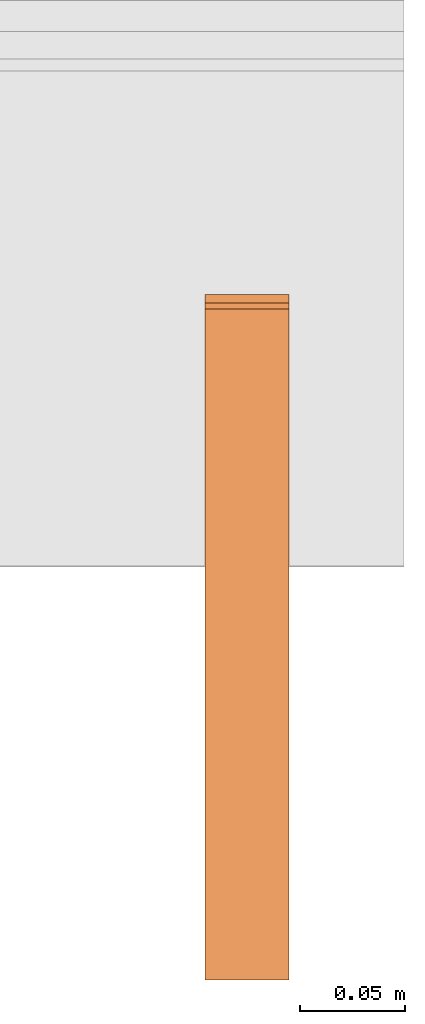
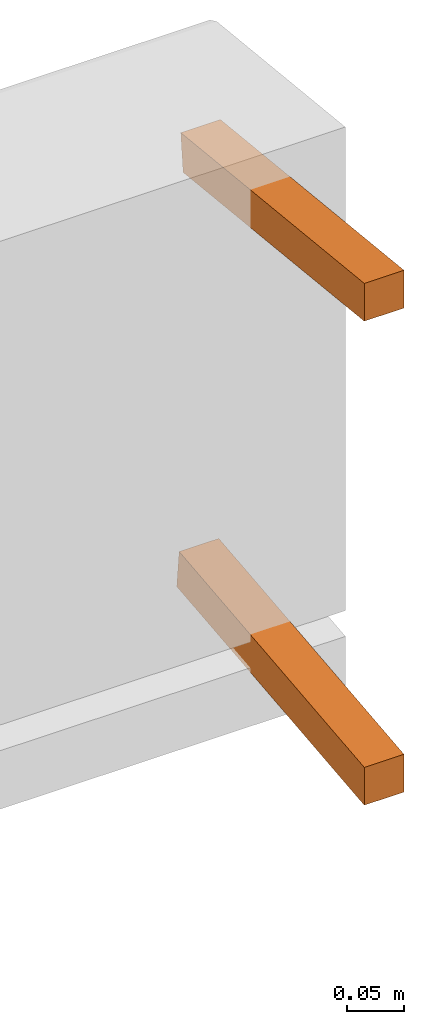
# One storey, part 2 of 2: 2 proxies, 1 element without a shape of its own.
"""IFC2X3 building model written with IfcOpenShell, lengths in metres."""

from ifc_helpers import new_model, si_unit, direction, origin_with_axes, place, context, project, spatial, faceted_brep, source, transform, mapped, element, aggregate, save


model = new_model("IFC2X3")

# Units and contexts
model_context = context("Model", 3, precision=1e-06, world=origin_with_axes(), true_north=direction((0.0, 1.0, 0.0)))
ifc_project = project(units=[si_unit("LENGTHUNIT", "METRE"), si_unit("AREAUNIT", "SQUARE_METRE"), si_unit("VOLUMEUNIT", "CUBIC_METRE")], contexts=[model_context])

# Site, building, storey
site_placement = place(None, origin_with_axes())
site = spatial("IfcSite", under=ifc_project, at=site_placement, CompositionType="ELEMENT")
building_placement = place(site_placement, origin_with_axes())
building = spatial("IfcBuilding", under=site, at=building_placement, Name="Default Building", CompositionType="ELEMENT")
storey_placement = place(building_placement, origin_with_axes())
storey = spatial("IfcBuildingStorey", under=building, at=storey_placement, Name="Default Storey", CompositionType="ELEMENT", Elevation=0.0)

# Assembly, proxies
assembly_placement = place(storey_placement, origin_with_axes())
assembly = element("IfcElementAssembly", 1, at=assembly_placement, inside=storey, AssemblyPlace="NOTDEFINED", PredefinedType="NOTDEFINED")
shared_shape_1 = source(origin_with_axes(), model_context, "Body", "Brep", [
    faceted_brep([(0.550000011920929, -0.3086836636066437, 0.203923761844635), (0.550000011920929, -0.3086836636066437, 0.24414409697055817), (0.5099999904632568, -0.3086836636066437, 0.203923761844635), (0.5099999904632568, -0.3086836636066437, 0.203923761844635), (0.550000011920929, -0.3086836636066437, 0.24414409697055817), (0.5099999904632568, -0.3086836636066437, 0.24414409697055817), (0.550000011920929, 0.00747277494519949, 0.17069438099861145), (0.550000011920929, -0.3086836636066437, 0.203923761844635), (0.5099999904632568, 0.00747277494519949, 0.17069438099861145), (0.5099999904632568, 0.00747277494519949, 0.17069438099861145), (0.550000011920929, -0.3086836636066437, 0.203923761844635), (0.5099999904632568, -0.3086836636066437, 0.203923761844635), (0.550000011920929, 0.011653914116322994, 0.21047525107860565), (0.550000011920929, 0.00747277494519949, 0.17069438099861145), (0.5099999904632568, 0.011653914116322994, 0.21047525107860565), (0.5099999904632568, 0.011653914116322994, 0.21047525107860565), (0.550000011920929, 0.00747277494519949, 0.17069438099861145), (0.5099999904632568, 0.00747277494519949, 0.17069438099861145), (0.550000011920929, -0.3086836636066437, 0.24414409697055817), (0.550000011920929, 0.011653914116322994, 0.21047525107860565), (0.5099999904632568, -0.3086836636066437, 0.24414409697055817), (0.5099999904632568, -0.3086836636066437, 0.24414409697055817), (0.550000011920929, 0.011653914116322994, 0.21047525107860565), (0.5099999904632568, 0.011653914116322994, 0.21047525107860565), (0.550000011920929, 0.00747277494519949, 0.17069438099861145), (0.550000011920929, 0.011653914116322994, 0.21047525107860565), (0.550000011920929, -0.3086836636066437, 0.203923761844635), (0.550000011920929, -0.3086836636066437, 0.203923761844635), (0.550000011920929, 0.011653914116322994, 0.21047525107860565), (0.550000011920929, -0.3086836636066437, 0.24414409697055817), (0.5099999904632568, 0.011653914116322994, 0.21047525107860565), (0.5099999904632568, 0.00747277494519949, 0.17069438099861145), (0.5099999904632568, -0.3086836636066437, 0.24414409697055817), (0.5099999904632568, -0.3086836636066437, 0.24414409697055817), (0.5099999904632568, 0.00747277494519949, 0.17069438099861145), (0.5099999904632568, -0.3086836636066437, 0.203923761844635)], [[[0, 1, 2]], [[3, 4, 5]], [[6, 7, 8]], [[9, 10, 11]], [[12, 13, 14]], [[15, 16, 17]], [[18, 19, 20]], [[21, 22, 23]], [[24, 25, 26]], [[27, 28, 29]], [[30, 31, 32]], [[33, 34, 35]]]),
])
proxy_1_placement = place(assembly_placement, origin_with_axes())
proxy_1 = element("IfcBuildingElementProxy", 2, at=proxy_1_placement, Name="4", ObjectType="4", CompositionType="ELEMENT", context=model_context, shape_type="MappedRepresentation", body=[
    mapped(shared_shape_1, transform((0.0, 0.0, 0.0), scale=1.0)),
])
shared_shape_2 = source(origin_with_axes(), model_context, "Body", "Brep", [
    faceted_brep([(0.550000011920929, -0.3086836636066437, -0.2712950110435486), (0.550000011920929, 0.014434427954256535, -0.23733393847942352), (0.5099999904632568, -0.3086836636066437, -0.2712950110435486), (0.5099999904632568, -0.3086836636066437, -0.2712950110435486), (0.550000011920929, 0.014434427954256535, -0.23733393847942352), (0.5099999904632568, 0.014434427954256535, -0.23733393847942352), (0.550000011920929, -0.3086836636066437, -0.31151533126831055), (0.550000011920929, -0.3086836636066437, -0.2712950110435486), (0.5099999904632568, -0.3086836636066437, -0.31151533126831055), (0.5099999904632568, -0.3086836636066437, -0.31151533126831055), (0.550000011920929, -0.3086836636066437, -0.2712950110435486), (0.5099999904632568, -0.3086836636066437, -0.2712950110435486), (0.550000011920929, 0.018615566194057465, -0.2771148085594177), (0.550000011920929, -0.3086836636066437, -0.31151533126831055), (0.5099999904632568, 0.018615566194057465, -0.2771148085594177), (0.5099999904632568, 0.018615566194057465, -0.2771148085594177), (0.550000011920929, -0.3086836636066437, -0.31151533126831055), (0.5099999904632568, -0.3086836636066437, -0.31151533126831055), (0.550000011920929, 0.014434427954256535, -0.23733393847942352), (0.550000011920929, 0.018615566194057465, -0.2771148085594177), (0.5099999904632568, 0.014434427954256535, -0.23733393847942352), (0.5099999904632568, 0.014434427954256535, -0.23733393847942352), (0.550000011920929, 0.018615566194057465, -0.2771148085594177), (0.5099999904632568, 0.018615566194057465, -0.2771148085594177), (0.550000011920929, -0.3086836636066437, -0.31151533126831055), (0.550000011920929, 0.018615566194057465, -0.2771148085594177), (0.550000011920929, -0.3086836636066437, -0.2712950110435486), (0.550000011920929, -0.3086836636066437, -0.2712950110435486), (0.550000011920929, 0.018615566194057465, -0.2771148085594177), (0.550000011920929, 0.014434427954256535, -0.23733393847942352), (0.5099999904632568, 0.018615566194057465, -0.2771148085594177), (0.5099999904632568, -0.3086836636066437, -0.31151533126831055), (0.5099999904632568, 0.014434427954256535, -0.23733393847942352), (0.5099999904632568, 0.014434427954256535, -0.23733393847942352), (0.5099999904632568, -0.3086836636066437, -0.31151533126831055), (0.5099999904632568, -0.3086836636066437, -0.2712950110435486)], [[[0, 1, 2]], [[3, 4, 5]], [[6, 7, 8]], [[9, 10, 11]], [[12, 13, 14]], [[15, 16, 17]], [[18, 19, 20]], [[21, 22, 23]], [[24, 25, 26]], [[27, 28, 29]], [[30, 31, 32]], [[33, 34, 35]]]),
])
proxy_2_placement = place(assembly_placement, origin_with_axes())
proxy_2 = element("IfcBuildingElementProxy", 3, at=proxy_2_placement, Name="5", ObjectType="5", CompositionType="ELEMENT", context=model_context, shape_type="MappedRepresentation", body=[
    mapped(shared_shape_2, transform((0.0, 0.0, 0.0), scale=1.0)),
])
aggregate(assembly, [proxy_1, proxy_2])

save(model, "model.ifc")
